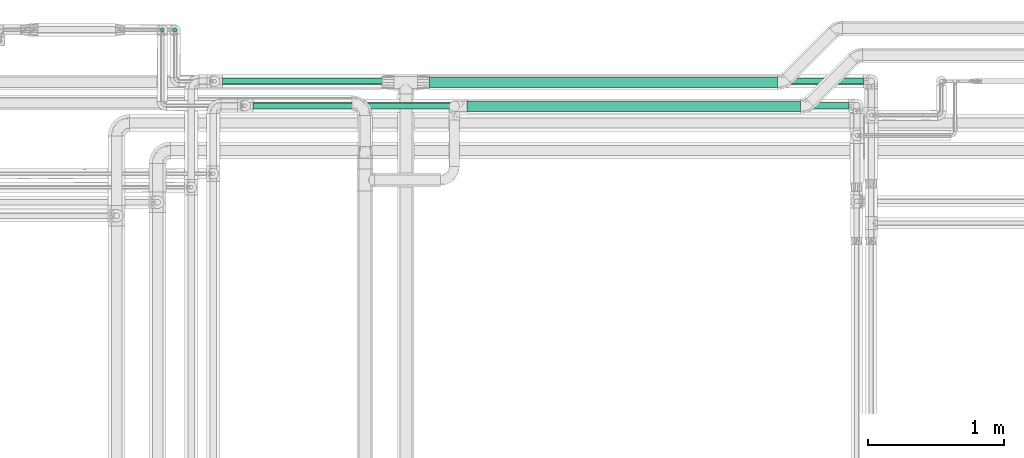
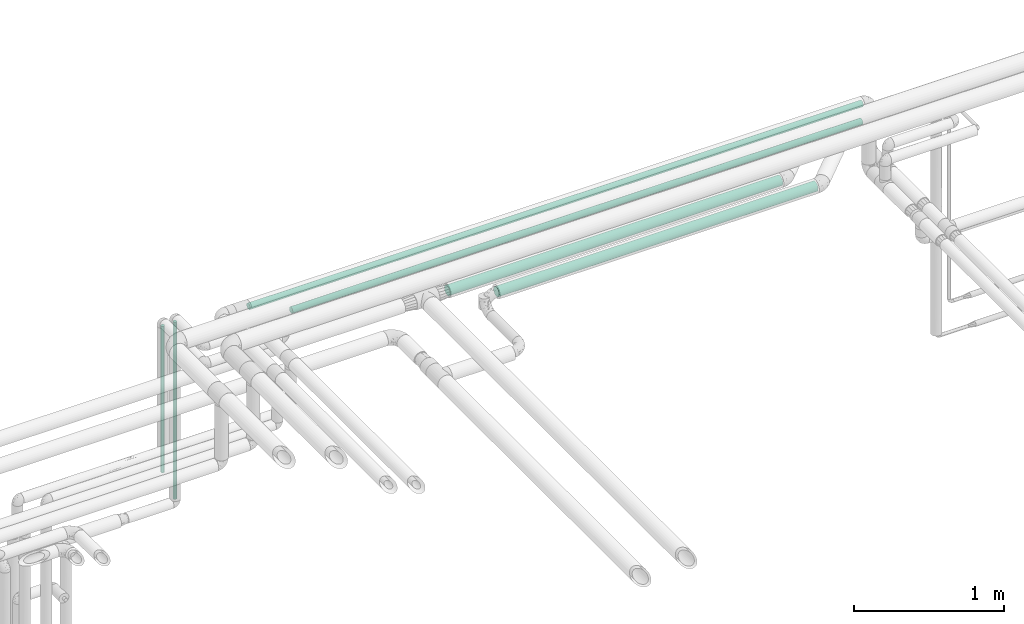
# One storey, part 536 of 827: 6 flow segments.
"""IFC2X3 building model written with IfcOpenShell, lengths in millimetres."""

from ifc_helpers import new_model, entity, si_unit, converted_unit, derived_unit, direction, frame, origin, origin_2d_with_axis, place, context, subcontext, project, spatial, circle, extrude, type_object, element, save


model = new_model("IFC2X3")

# Units and contexts
model_context = context("Model", 3, precision=0.01, world=origin(), true_north=direction((6.12303176911189e-17, 1.0)))
body_context = subcontext(model_context, "Body", "Model", "MODEL_VIEW")
ifc_project = project(units=[si_unit("LENGTHUNIT", "METRE", prefix="MILLI"), si_unit("AREAUNIT", "SQUARE_METRE"), si_unit("VOLUMEUNIT", "CUBIC_METRE"), converted_unit("PLANEANGLEUNIT", "DEGREE", entity("IfcRatioMeasure", 0.0174532925199433), si_unit("PLANEANGLEUNIT", "RADIAN"), dimensions=[0, 0, 0, 0, 0, 0, 0]), si_unit("MASSUNIT", "GRAM", prefix="KILO"), derived_unit("MASSDENSITYUNIT", [(si_unit("MASSUNIT", "GRAM", prefix="KILO"), 1), (si_unit("LENGTHUNIT", "METRE"), -3)]), derived_unit("MOMENTOFINERTIAUNIT", [(si_unit("LENGTHUNIT", "METRE"), 4)]), si_unit("TIMEUNIT", "SECOND"), si_unit("FREQUENCYUNIT", "HERTZ"), si_unit("THERMODYNAMICTEMPERATUREUNIT", "DEGREE_CELSIUS"), derived_unit("THERMALTRANSMITTANCEUNIT", [(si_unit("MASSUNIT", "GRAM", prefix="KILO"), 1), (si_unit("THERMODYNAMICTEMPERATUREUNIT", "KELVIN"), -1), (si_unit("TIMEUNIT", "SECOND"), -3)]), derived_unit("VOLUMETRICFLOWRATEUNIT", [(si_unit("LENGTHUNIT", "METRE"), 3), (si_unit("TIMEUNIT", "SECOND"), -1)]), derived_unit("MASSFLOWRATEUNIT", [(si_unit("MASSUNIT", "GRAM", prefix="KILO"), 1), (si_unit("TIMEUNIT", "SECOND"), -1)]), derived_unit("ROTATIONALFREQUENCYUNIT", [(si_unit("TIMEUNIT", "SECOND"), -1)]), si_unit("ELECTRICCURRENTUNIT", "AMPERE"), si_unit("ELECTRICVOLTAGEUNIT", "VOLT"), si_unit("POWERUNIT", "WATT"), si_unit("FORCEUNIT", "NEWTON", prefix="KILO"), si_unit("ILLUMINANCEUNIT", "LUX"), si_unit("LUMINOUSFLUXUNIT", "LUMEN"), si_unit("LUMINOUSINTENSITYUNIT", "CANDELA"), derived_unit("USERDEFINED", [(si_unit("MASSUNIT", "GRAM", prefix="KILO"), -1), (si_unit("LENGTHUNIT", "METRE"), -2), (si_unit("TIMEUNIT", "SECOND"), 3), (si_unit("LUMINOUSFLUXUNIT", "LUMEN"), 1)]), derived_unit("LINEARVELOCITYUNIT", [(si_unit("LENGTHUNIT", "METRE"), 1), (si_unit("TIMEUNIT", "SECOND"), -1)]), si_unit("PRESSUREUNIT", "PASCAL"), derived_unit("USERDEFINED", [(si_unit("LENGTHUNIT", "METRE"), -2), (si_unit("MASSUNIT", "GRAM", prefix="KILO"), 1), (si_unit("TIMEUNIT", "SECOND"), -2)]), derived_unit("LINEARFORCEUNIT", [(si_unit("MASSUNIT", "GRAM", prefix="KILO"), 1), (si_unit("LENGTHUNIT", "METRE"), 1), (si_unit("TIMEUNIT", "SECOND"), -2), (si_unit("LENGTHUNIT", "METRE"), -1)]), derived_unit("PLANARFORCEUNIT", [(si_unit("MASSUNIT", "GRAM", prefix="KILO"), 1), (si_unit("LENGTHUNIT", "METRE"), 1), (si_unit("TIMEUNIT", "SECOND"), -2), (si_unit("LENGTHUNIT", "METRE"), -2)])], contexts=[model_context])

# Site, building, storey
site_placement = place(None, origin())
site = spatial("IfcSite", under=ifc_project, at=site_placement, CompositionType="ELEMENT")
building_placement = place(site_placement, origin())
building = spatial("IfcBuilding", under=site, at=building_placement, CompositionType="ELEMENT")
storey_placement = place(building_placement, frame((0.0, 0.0, 28200.0)))
storey = spatial("IfcBuildingStorey", under=building, at=storey_placement, Name="08", CompositionType="ELEMENT", Elevation=28200.0)

# Flow segments
pipe_segment_type_1 = type_object("IfcPipeSegmentType", PredefinedType="NOTDEFINED")
flow_segment_1_placement = place(storey_placement, frame((38223.3, 19068.12, 2960.4)))
element("IfcFlowSegment", 1, at=flow_segment_1_placement, inside=storey, type_object=pipe_segment_type_1, context=body_context, shape_type="SweptSolid", body=[
    extrude(circle(Radius=38.0, at=origin_2d_with_axis()), frame((0.0, 39.6, 39.6), z_axis=(1.0, 0.0, 0.0), x_axis=(0.0, 1.0, 0.0)), (0.0, 0.0, 1.0), 2563.05314198827),
])
pipe_segment_type_2 = type_object("IfcPipeSegmentType", PredefinedType="NOTDEFINED")
flow_segment_2_placement = place(storey_placement, frame((38500.22, 18892.0, 2960.65)))
element("IfcFlowSegment", 2, at=flow_segment_2_placement, inside=storey, type_object=pipe_segment_type_2, context=body_context, shape_type="SweptSolid", body=[
    extrude(circle(Radius=37.75, at=origin_2d_with_axis()), frame((0.0, 39.35, 39.35), z_axis=(1.0, 0.0, 0.0), x_axis=(0.0, 1.0, 0.0)), (0.0, 0.0, 1.0), 2456.78207897576),
])
flow_segment_3_placement = place(storey_placement, frame((36922.02, 18910.81, 3374.3)))
element("IfcFlowSegment", 3, at=flow_segment_3_placement, inside=storey, type_object=pipe_segment_type_2, context=body_context, shape_type="SweptSolid", body=[
    extrude(circle(Radius=24.0, at=origin_2d_with_axis()), frame((0.0, 25.6, 25.6), z_axis=(1.0, 1.42382432847069e-05, 0.0), x_axis=(-1.42382432847069e-05, 1.0, 0.0)), (0.0, 0.0, 1.0), 4390.35001608479),
])
flow_segment_4_placement = place(storey_placement, frame((36335.03, 19479.61, 1729.1)))
element("IfcFlowSegment", 4, at=flow_segment_4_placement, inside=storey, type_object=pipe_segment_type_2, context=body_context, shape_type="SweptSolid", body=[
    extrude(circle(Radius=13.4, at=origin_2d_with_axis()), frame((15.0, 15.0, 0.0), z_axis=(0.0, 0.0, 1.0), x_axis=(-1.0, 0.0, 0.0)), (0.0, 0.0, 1.0), 1441.80000000001),
])
flow_segment_5_placement = place(storey_placement, frame((36240.03, 19479.61, 1979.1)))
element("IfcFlowSegment", 5, at=flow_segment_5_placement, inside=storey, type_object=pipe_segment_type_2, context=body_context, shape_type="SweptSolid", body=[
    extrude(circle(Radius=13.4, at=origin_2d_with_axis()), frame((15.0, 15.0, 0.0), z_axis=(0.0, -3.19741188361788e-08, 1.0), x_axis=(-1.0, 0.0, 0.0)), (0.0, 0.0, 1.0), 1191.80000000005),
])
flow_segment_6_placement = place(storey_placement, frame((36697.02, 19089.89, 3374.3)))
element("IfcFlowSegment", 6, at=flow_segment_6_placement, inside=storey, type_object=pipe_segment_type_2, context=body_context, shape_type="SweptSolid", body=[
    extrude(circle(Radius=24.0, at=origin_2d_with_axis()), frame((0.0, 25.6, 25.6), z_axis=(1.0, 0.0, 0.0), x_axis=(0.0, 1.0, 0.0)), (0.0, 0.0, 1.0), 4722.19367836544),
])

save(model, "model.ifc")
